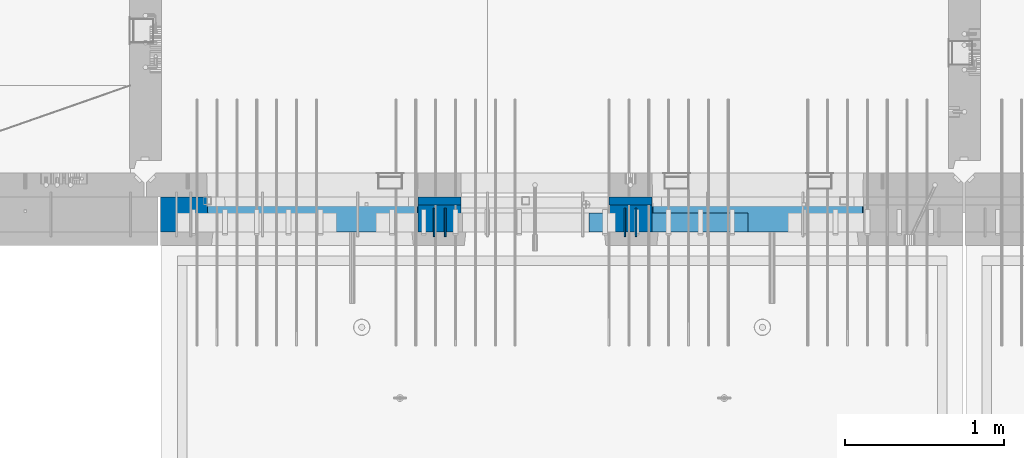
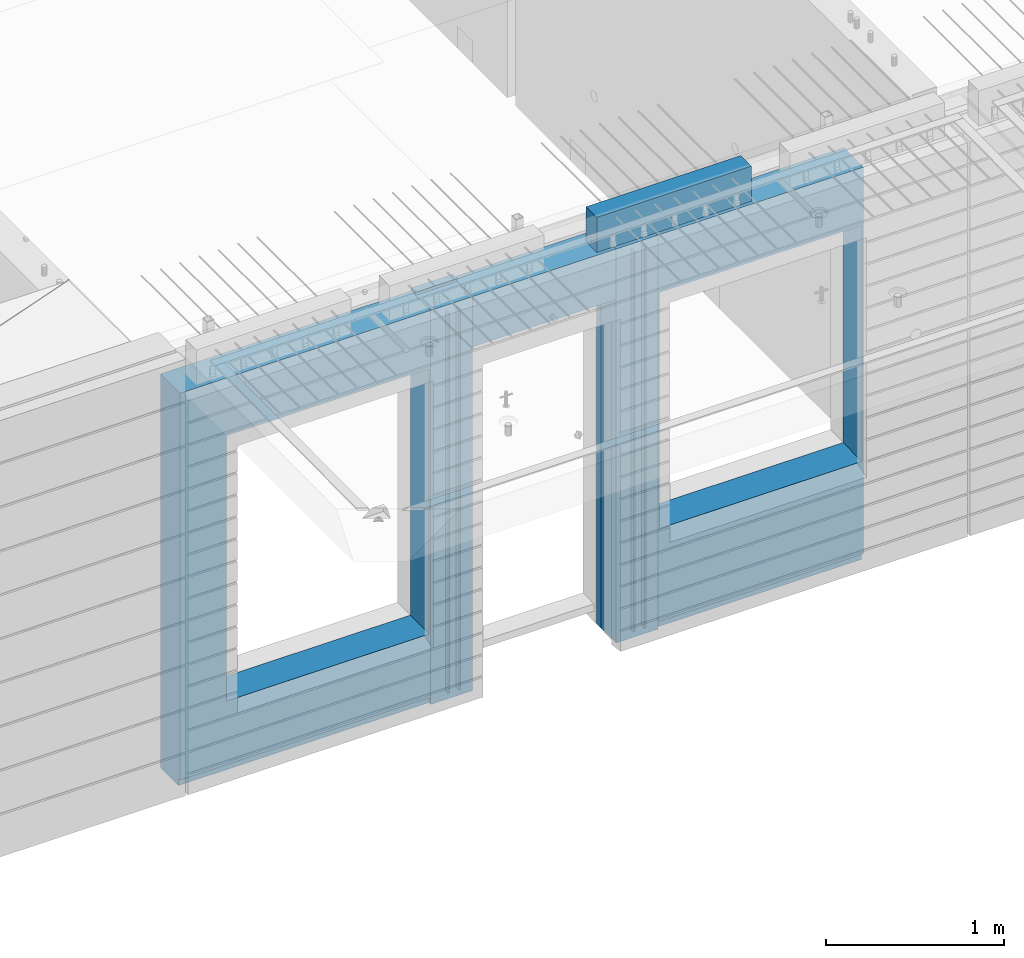
# One storey, part 229 of 349: 10 walls, 3 elements without a shape of their own.
"""IFC2X3 building model written with IfcOpenShell, lengths in millimetres."""

from ifc_helpers import new_model, si_unit, frame, origin_with_axes, place, context, subcontext, project, spatial, faceted_brep, material, type_object, element, aggregate, save


model = new_model("IFC2X3")

# Units and contexts
model_context = context("Model", 3, precision=1e-05, world=origin_with_axes())
body_context = subcontext(model_context, "Body", "Model", "MODEL_VIEW")
ifc_project = project(units=[si_unit("LENGTHUNIT", "METRE", prefix="MILLI"), si_unit("AREAUNIT", "SQUARE_METRE"), si_unit("VOLUMEUNIT", "CUBIC_METRE"), si_unit("MASSUNIT", "GRAM", prefix="KILO"), si_unit("TIMEUNIT", "SECOND"), si_unit("PLANEANGLEUNIT", "RADIAN"), si_unit("SOLIDANGLEUNIT", "STERADIAN"), si_unit("THERMODYNAMICTEMPERATUREUNIT", "DEGREE_CELSIUS"), si_unit("LUMINOUSINTENSITYUNIT", "LUMEN")], contexts=[model_context])

# Site, building, storey
site_placement = place(None, origin_with_axes())
site = spatial("IfcSite", under=ifc_project, at=site_placement, CompositionType="ELEMENT")
building_placement = place(site_placement, origin_with_axes())
building = spatial("IfcBuilding", under=site, at=building_placement, CompositionType="ELEMENT")
storey_placement = place(building_placement, origin_with_axes())
storey = spatial("IfcBuildingStorey", under=building, at=storey_placement, Name="4", CompositionType="ELEMENT", Elevation=0.0)

# Assembly, walls
assembly_1_placement = place(storey_placement, origin_with_axes())
assembly_1 = element("IfcElementAssembly", 1, at=assembly_1_placement, inside=storey, AssemblyPlace="NOTDEFINED", PredefinedType="REINFORCEMENT_UNIT")
ifc_material_1 = material(Name="Undefined")
wall_type_1 = type_object("IfcWallType", PredefinedType="NOTDEFINED")
wall_1_placement = place(assembly_1_placement, frame((18475.0, 7780.0, 92115.0), z_axis=(0.0, 0.0, 1.0), x_axis=(0.0, -1.0, 0.0)))
wall_1 = element("IfcWall", 2, at=wall_1_placement, type_object=wall_type_1, material=ifc_material_1, Name="(PD)", context=body_context, shape_type="Brep", body=[
    faceted_brep([(0.0, 5.0, -1300.0), (0.0, 5.0, 1300.0), (180.0, 5.0, 1300.0), (180.0, 5.0, -1300.0), (0.0, -5.0, 1300.0), (180.0, -5.0, 1300.0), (0.0, -5.0, -1300.0), (180.0, -5.0, -1300.0)], [[[0, 1, 2, 3]], [[1, 4, 5, 2]], [[4, 6, 7, 5]], [[6, 0, 3, 7]], [[5, 7, 3, 2]], [[6, 4, 1, 0]]]),
])
wall_2_placement = place(assembly_1_placement, frame((18545.0, 7780.0, 92115.0), z_axis=(0.0, 0.0, 1.0), x_axis=(0.0, -1.0, 0.0)))
wall_2 = element("IfcWall", 3, at=wall_2_placement, type_object=wall_type_1, material=ifc_material_1, Name="(PD)", context=body_context, shape_type="Brep", body=[
    faceted_brep([(0.0, 5.0, -1300.0), (0.0, 5.0, 1300.0), (180.0, 5.0, 1300.0), (180.0, 5.0, -1300.0), (0.0, -5.0, 1300.0), (180.0, -5.0, 1300.0), (0.0, -5.0, -1300.0), (180.0, -5.0, -1300.0)], [[[0, 1, 2, 3]], [[1, 4, 5, 2]], [[4, 6, 7, 5]], [[6, 0, 3, 7]], [[5, 7, 3, 2]], [[6, 4, 1, 0]]]),
])
wall_3_placement = place(assembly_1_placement, frame((19675.0, 7779.99999999997, 92115.0), z_axis=(0.0, 0.0, 1.0), x_axis=(0.0, -1.0, 0.0)))
wall_3 = element("IfcWall", 4, at=wall_3_placement, type_object=wall_type_1, material=ifc_material_1, Name="(PD)", context=body_context, shape_type="Brep", body=[
    faceted_brep([(0.0, 5.0, -1300.0), (0.0, 5.0, 1300.0), (180.0, 5.0, 1300.0), (180.0, 5.0, -1300.0), (0.0, -5.0, 1300.0), (180.0, -5.0, 1300.0), (0.0, -5.0, -1300.0), (180.0, -5.0, -1300.0)], [[[0, 1, 2, 3]], [[1, 4, 5, 2]], [[4, 6, 7, 5]], [[6, 0, 3, 7]], [[5, 7, 3, 2]], [[6, 4, 1, 0]]]),
])
wall_4_placement = place(assembly_1_placement, frame((19745.0, 7780.0, 92115.0), z_axis=(0.0, 0.0, 1.0), x_axis=(0.0, -1.0, 0.0)))
wall_4 = element("IfcWall", 5, at=wall_4_placement, type_object=wall_type_1, material=ifc_material_1, Name="(PD)", context=body_context, shape_type="Brep", body=[
    faceted_brep([(0.0, 5.0, -1300.0), (0.0, 5.0, 1300.0), (180.0, 5.0, 1300.0), (180.0, 5.0, -1300.0), (0.0, -5.0, 1300.0), (180.0, -5.0, 1300.0), (0.0, -5.0, -1300.0), (180.0, -5.0, -1300.0)], [[[0, 1, 2, 3]], [[1, 4, 5, 2]], [[4, 6, 7, 5]], [[6, 0, 3, 7]], [[5, 7, 3, 2]], [[6, 4, 1, 0]]]),
])

# Assemblies, wall
assembly_2_placement = place(storey_placement, origin_with_axes())
assembly_2 = element("IfcElementAssembly", 6, at=assembly_2_placement, inside=storey, AssemblyPlace="NOTDEFINED", PredefinedType="REINFORCEMENT_UNIT")
assembly_3_placement = place(assembly_2_placement, origin_with_axes())
assembly_3 = element("IfcElementAssembly", 7, at=assembly_3_placement, Name="Steel Assembly", AssemblyPlace="NOTDEFINED", PredefinedType="NOTDEFINED")
aggregate(assembly_2, [assembly_3])
ifc_material_2 = material()
wall_type_2 = type_object("IfcWallType", PredefinedType="NOTDEFINED")
wall_5_placement = place(assembly_3_placement, frame((19449.9998568133, 7690.00021946163, 93590.0), z_axis=(0.0, 0.0, 1.0), x_axis=(1.0, 0.0, 0.0)))
wall_5 = element("IfcWall", 8, at=wall_5_placement, type_object=wall_type_2, material=ifc_material_2, context=body_context, shape_type="Brep", body=[
    faceted_brep([(0.0, 60.0, -120.0), (0.0, 60.0, 120.0), (1000.0, 60.0, 120.0), (1000.0, 60.0, -120.0), (0.0, -60.0, 120.0), (1000.0, -60.0, 120.0), (0.0, -60.0, -120.0), (1000.0, -60.0, -120.0)], [[[0, 1, 2, 3]], [[1, 4, 5, 2]], [[4, 6, 7, 5]], [[6, 0, 3, 7]], [[5, 7, 3, 2]], [[6, 4, 1, 0]]]),
])
aggregate(assembly_3, [wall_5])

# Wall
ifc_material_3 = material(Name="CONCRETE/C35/45")
wall_type_3 = type_object("IfcWallType", PredefinedType="NOTDEFINED")
wall_6_placement = place(assembly_1_placement, frame((18645.0200381475, 7825.0, 92112.5), z_axis=(0.0, 0.0, 1.0), x_axis=(-1.0, 3.00000001838171e-08, 0.0)))
wall_6 = element("IfcWall", 9, at=wall_6_placement, type_object=wall_type_3, material=ifc_material_3, context=body_context, shape_type="Brep", body=[
    faceted_brep([(0.0, 25.0, -1357.5), (0.0, 25.0, 1357.5), (270.001908754726, 25.0, 1357.5), (270.001908754726, 25.0, -1357.5), (0.0, -25.0, 1357.5), (270.001908754726, -25.0, 1357.5), (0.0, -25.0, -1357.5), (270.001908754726, -25.0, -1357.5)], [[[0, 1, 2, 3]], [[1, 4, 5, 2]], [[4, 6, 7, 5]], [[6, 0, 3, 7]], [[5, 7, 3, 2]], [[6, 4, 1, 0]]]),
])

wall_7_placement = place(assembly_1_placement, frame((19845.0100381475, 7825.0, 92112.5), z_axis=(0.0, 0.0, 1.0), x_axis=(-1.0, 3.00000001838171e-08, 0.0)))
wall_7 = element("IfcWall", 10, at=wall_7_placement, type_object=wall_type_3, material=ifc_material_3, context=body_context, shape_type="Brep", body=[
    faceted_brep([(0.0, 25.0, -1357.5), (0.0, 25.0, 1357.5), (270.001908754726, 25.0, 1357.5), (270.001908754726, 25.0, -1357.5), (0.0, -25.0, 1357.5), (270.001908754726, -25.0, 1357.5), (0.0, -25.0, -1357.5), (270.001908754726, -25.0, -1357.5)], [[[0, 1, 2, 3]], [[1, 4, 5, 2]], [[4, 6, 7, 5]], [[6, 0, 3, 7]], [[5, 7, 3, 2]], [[6, 4, 1, 0]]]),
])

ifc_material_4 = material(Name="SPU")
wall_type_4 = type_object("IfcWallType", PredefinedType="NOTDEFINED")
wall_8_placement = place(assembly_1_placement, frame((18645.0100381475, 7715.0, 92102.5), z_axis=(0.0, 0.0, 1.0), x_axis=(-1.0, 3.00000001838171e-08, 0.0)))
wall_8 = element("IfcWall", 11, at=wall_8_placement, type_object=wall_type_4, material=ifc_material_4, context=body_context, shape_type="Brep", body=[
    faceted_brep([(0.0, 85.0, -1347.5), (0.0, 85.0, 1347.5), (270.001908754726, 85.0, 1347.5), (270.001908754726, 85.0, -1347.5), (0.0, -85.0, 1347.5), (270.001908754726, -85.0, 1347.5), (0.0, -85.0, -1347.5), (270.001908754726, -85.0, -1347.5)], [[[0, 1, 2, 3]], [[1, 4, 5, 2]], [[4, 6, 7, 5]], [[6, 0, 3, 7]], [[5, 7, 3, 2]], [[6, 4, 1, 0]]]),
])

wall_9_placement = place(assembly_1_placement, frame((19845.0100381475, 7715.0, 92102.5), z_axis=(0.0, 0.0, 1.0), x_axis=(-1.0, 3.00000001838171e-08, 0.0)))
wall_9 = element("IfcWall", 12, at=wall_9_placement, type_object=wall_type_4, material=ifc_material_4, context=body_context, shape_type="Brep", body=[
    faceted_brep([(0.0, 85.0, -1347.5), (0.0, 85.0, 1347.5), (270.001908754726, 85.0, 1347.5), (270.001908754726, 85.0, -1347.5), (0.0, -85.0, 1347.5), (270.001908754726, -85.0, 1347.5), (0.0, -85.0, -1347.5), (270.001908754726, -85.0, -1347.5)], [[[0, 1, 2, 3]], [[1, 4, 5, 2]], [[4, 6, 7, 5]], [[6, 0, 3, 7]], [[5, 7, 3, 2]], [[6, 4, 1, 0]]]),
])

ifc_material_5 = material(Name="COS5gt")
wall_type_5 = type_object("IfcWallType", PredefinedType="NOTDEFINED")
wall_10_placement = place(assembly_1_placement, frame((21175.0, 7740.0, 92102.5), z_axis=(0.0, 0.0, 1.0), x_axis=(-1.0, 3.00000001838171e-08, 0.0)))
wall_10 = element("IfcWall", 13, at=wall_10_placement, type_object=wall_type_5, material=ifc_material_5, context=body_context, shape_type="Brep", body=[
    faceted_brep([(4420.0, -110.0, 1347.5), (4420.0, 110.0, 1347.5), (2799.99187060721, 110.0, 1347.5), (2799.99187060721, -10.0, 1347.5), (2799.9818706072, -110.0, 1347.5), (4420.0, 110.0, -1297.5), (4420.0, 90.0, -1297.5), (2799.99187060721, 90.0, -1297.5), (2799.99187060721, 110.0, -1297.5), (4420.0, -110.0, -1347.5), (4420.0, 90.0, -1347.5), (2799.99187060721, 90.0, -1347.5), (2799.99187060721, -10.0, -1347.5), (2809.99937278789, 110.0, -862.5), (2839.99937278789, 110.0, -862.5), (4089.99937278789, 110.0, -862.5), (4119.99937278789, 110.0, -862.5), (4119.99937278789, 110.0, -857.5), (4119.99937278789, 110.0, 952.5), (2809.99937278789, 110.0, 952.5), (2809.99937278789, 110.0, -857.5), (2804.05342684194, -110.0, -868.445945945947), (2804.05342684194, -109.999999999999, 958.445945945947), (4125.94531873383, -110.0, -868.445945945947), (4125.94531873383, -109.999999999999, 958.445945945947), (2799.9818706072, -110.0, -1347.5), (1329.98996185248, -110.0, 1347.5), (1329.98996185248, -110.0, -1347.5), (1329.98996185248, -10.0, -1347.5), (1329.98996185248, -10.0, 1347.5), (0.0, -110.0, -1347.5), (0.0, 90.0, -1347.5), (1329.98996185248, 90.0, -1347.5), (0.0, 90.0, -1297.5), (0.0, 110.0, -1297.5), (1329.98996185248, 110.0, -1297.5), (1329.98996185248, 90.0, -1297.5), (0.0, -110.0, 1347.5), (0.0, 110.0, 1347.5), (1329.98996185248, 110.0, 1347.5), (10.0001357273395, 110.0, -662.5), (40.0001357273395, 110.0, -662.5), (1290.00013572734, 110.0, -662.5), (1320.00013572734, 110.0, -662.5), (1320.00013572734, 110.0, -657.5), (1320.00013572734, 110.0, 952.5), (10.0001357273395, 110.0, 952.5), (10.0001357273395, 110.0, -657.5), (4.05418978139278, -110.0, -668.445945945947), (4.05418978139278, -109.999999999999, 958.445945945947), (1325.94608167329, -110.0, -668.445945945947), (1325.94608167329, -109.999999999999, 958.445945945947), (1600.00051719707, -109.999999999999, 1002.5), (1599.99187060721, -110.0, 1347.5), (1599.99187060721, -10.0, 1347.5), (1600.00051719707, -10.0, 1002.5), (1600.00051719707, 110.0, 1002.5), (1599.99187060721, 110.0, 1347.5), (2529.98996185248, 110.0, 1347.5), (2529.98996185248, 110.0, 1002.5), (2529.98996185248, -10.0, 1347.5), (2529.98996185248, -10.0, 1002.5), (2529.97996185248, -110.0, 1347.5), (2529.97996185248, -109.999999999999, 1002.5)], [[[0, 1, 2, 3, 4]], [[5, 6, 7, 8]], [[1, 0, 9, 10, 6, 5]], [[6, 10, 11, 7]], [[2, 8, 7, 11, 12, 3]], [[1, 5, 8, 2], [13, 14, 15, 16, 17, 18, 19, 20]], [[21, 13, 20, 19, 22]], [[23, 16, 15, 14, 13, 21]], [[17, 16, 23, 24, 18]], [[22, 19, 18, 24]], [[9, 0, 4, 25], [23, 21, 22, 24]], [[11, 10, 9, 25, 12]], [[4, 3, 12, 25]], [[26, 27, 28, 29]], [[27, 30, 31, 32, 28]], [[33, 34, 35, 36]], [[31, 33, 36, 32]], [[30, 37, 38, 34, 33, 31]], [[38, 37, 26, 29, 39]], [[29, 28, 32, 36, 35, 39]], [[34, 38, 39, 35], [40, 41, 42, 43, 44, 45, 46, 47]], [[48, 40, 47, 46, 49]], [[50, 43, 42, 41, 40, 48]], [[44, 43, 50, 51, 45]], [[49, 46, 45, 51]], [[37, 30, 27, 26], [50, 48, 49, 51]], [[52, 53, 54, 55]], [[56, 57, 58, 59]], [[59, 58, 60, 61]], [[62, 63, 61, 60]], [[53, 52, 63, 62]], [[56, 59, 61, 63, 52, 55]], [[54, 57, 56, 55]], [[62, 60, 58, 57, 54, 53]]]),
])

aggregate(assembly_1, [wall_6, wall_8, wall_9, wall_1, wall_2, wall_7, wall_3, wall_4, wall_10])

save(model, "model.ifc")
